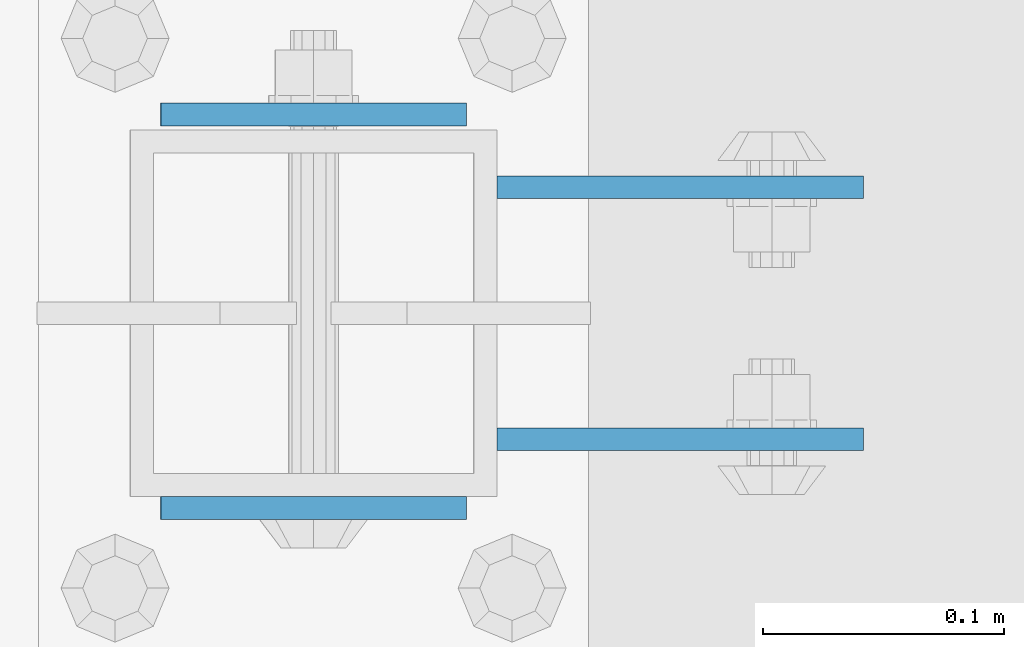
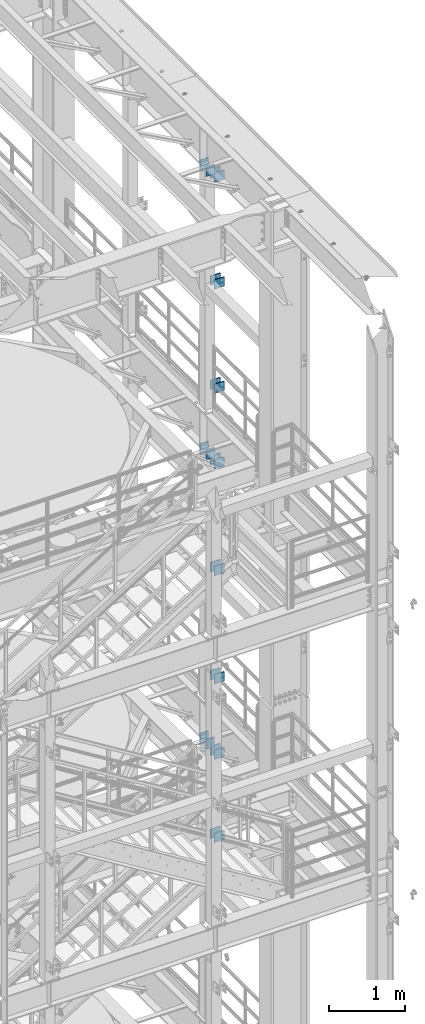
# One storey, part 1224 of 1876: 22 beams, 6 elements without a shape of their own.
"""IFC2X3 building model written with IfcOpenShell, lengths in millimetres."""

from ifc_helpers import new_model, si_unit, frame, origin_with_axes, place, context, subcontext, project, spatial, faceted_brep, material, type_object, element, aggregate, save


model = new_model("IFC2X3")

# Units and contexts
model_context = context("Model", 3, precision=1e-05, world=origin_with_axes())
body_context = subcontext(model_context, "Body", "Model", "MODEL_VIEW")
ifc_project = project(units=[si_unit("LENGTHUNIT", "METRE", prefix="MILLI"), si_unit("AREAUNIT", "SQUARE_METRE"), si_unit("VOLUMEUNIT", "CUBIC_METRE"), si_unit("MASSUNIT", "GRAM", prefix="KILO"), si_unit("TIMEUNIT", "SECOND"), si_unit("PLANEANGLEUNIT", "RADIAN"), si_unit("SOLIDANGLEUNIT", "STERADIAN"), si_unit("THERMODYNAMICTEMPERATUREUNIT", "DEGREE_CELSIUS"), si_unit("LUMINOUSINTENSITYUNIT", "LUMEN")], contexts=[model_context])

# Site, building, storey
site_placement = place(None, origin_with_axes())
site = spatial("IfcSite", under=ifc_project, at=site_placement, CompositionType="ELEMENT")
building_placement = place(site_placement, origin_with_axes())
building = spatial("IfcBuilding", under=site, at=building_placement, Name="Undefined", CompositionType="ELEMENT")
storey_placement = place(building_placement, origin_with_axes())
storey = spatial("IfcBuildingStorey", under=building, at=storey_placement, Name="Undefined", CompositionType="ELEMENT", Elevation=0.0)

# Assembly, beams
assembly_1_placement = place(storey_placement, origin_with_axes())
assembly_1 = element("IfcElementAssembly", 1, at=assembly_1_placement, inside=storey, Name="BEAM", AssemblyPlace="NOTDEFINED", PredefinedType="RIGID_FRAME")
ifc_material = material(Name="STEEL/A36")
beam_type_1 = type_object("IfcBeamType", PredefinedType="NOTDEFINED")
beam_1_placement = place(assembly_1_placement, frame((7696.20000025489, -2487.6125, 18275.3), z_axis=(0.0, 0.0, -1.0), x_axis=(1.0, 0.0, 0.0)))
beam_1 = element("IfcBeam", 2, at=beam_1_placement, type_object=beam_type_1, material=ifc_material, Name="PLATE", context=body_context, shape_type="Brep", body=[
    faceted_brep([(0.0, 4.76249999999982, -76.1999999999998), (3.63797880709171e-12, 4.76249999999982, 76.1999969482422), (152.399993896484, 4.76250000000073, 76.1999969482422), (152.4, 4.76249999999982, -76.1999999999998), (3.63797880709171e-12, -4.76249999999982, 76.1999969482422), (152.399993896484, -4.76250000000073, 76.1999969482422), (0.0, -4.76249999999982, -76.1999999999998), (152.4, -4.76249999999982, -76.1999999999998)], [[[0, 1, 2, 3]], [[4, 5, 2, 1]], [[4, 6, 7, 5]], [[6, 0, 3, 7]], [[5, 7, 3, 2]], [[6, 4, 1, 0]]]),
])
beam_2_placement = place(assembly_1_placement, frame((7696.20000025489, -2592.3875, 18275.3), z_axis=(0.0, 0.0, -1.0), x_axis=(1.0, 0.0, 0.0)))
beam_2 = element("IfcBeam", 3, at=beam_2_placement, type_object=beam_type_1, material=ifc_material, Name="PLATE", context=body_context, shape_type="Brep", body=[
    faceted_brep([(0.0, 4.76249999999982, -76.1999999999998), (3.63797880709171e-12, 4.76249999999982, 76.1999969482422), (152.399993896484, 4.76250000000073, 76.1999969482422), (152.4, 4.76249999999982, -76.1999999999998), (3.63797880709171e-12, -4.76249999999982, 76.1999969482422), (152.399993896484, -4.76250000000073, 76.1999969482422), (0.0, -4.76249999999982, -76.1999999999998), (152.4, -4.76249999999982, -76.1999999999998)], [[[0, 1, 2, 3]], [[4, 5, 2, 1]], [[4, 6, 7, 5]], [[6, 0, 3, 7]], [[5, 7, 3, 2]], [[6, 4, 1, 0]]]),
])
beam_3_placement = place(assembly_1_placement, frame((7696.20000025489, -2487.6125, 21678.9), z_axis=(0.0, 0.0, -1.0), x_axis=(1.0, 0.0, 0.0)))
beam_3 = element("IfcBeam", 4, at=beam_3_placement, type_object=beam_type_1, material=ifc_material, Name="PLATE", context=body_context, shape_type="Brep", body=[
    faceted_brep([(0.0, 4.76249999999982, -76.1999999999998), (3.63797880709171e-12, 4.76249999999982, 76.1999969482422), (152.399993896484, 4.76250000000073, 76.1999969482422), (152.4, 4.76249999999982, -76.1999999999998), (3.63797880709171e-12, -4.76249999999982, 76.1999969482422), (152.399993896484, -4.76250000000073, 76.1999969482422), (0.0, -4.76249999999982, -76.1999999999998), (152.4, -4.76249999999982, -76.1999999999998)], [[[0, 1, 2, 3]], [[4, 5, 2, 1]], [[4, 6, 7, 5]], [[6, 0, 3, 7]], [[5, 7, 3, 2]], [[6, 4, 1, 0]]]),
])
beam_4_placement = place(assembly_1_placement, frame((7696.20000025489, -2592.3875, 21678.9), z_axis=(0.0, 0.0, -1.0), x_axis=(1.0, 0.0, 0.0)))
beam_4 = element("IfcBeam", 5, at=beam_4_placement, type_object=beam_type_1, material=ifc_material, Name="PLATE", context=body_context, shape_type="Brep", body=[
    faceted_brep([(0.0, 4.76249999999982, -76.1999999999998), (3.63797880709171e-12, 4.76249999999982, 76.1999969482422), (152.399993896484, 4.76250000000073, 76.1999969482422), (152.4, 4.76249999999982, -76.1999999999998), (3.63797880709171e-12, -4.76249999999982, 76.1999969482422), (152.399993896484, -4.76250000000073, 76.1999969482422), (0.0, -4.76249999999982, -76.1999999999998), (152.4, -4.76249999999982, -76.1999999999998)], [[[0, 1, 2, 3]], [[4, 5, 2, 1]], [[4, 6, 7, 5]], [[6, 0, 3, 7]], [[5, 7, 3, 2]], [[6, 4, 1, 0]]]),
])
beam_5_placement = place(assembly_1_placement, frame((7696.20000025489, -2487.6125, 19958.05), z_axis=(0.0, 0.0, -1.0), x_axis=(1.0, 0.0, 0.0)))
beam_5 = element("IfcBeam", 6, at=beam_5_placement, type_object=beam_type_1, material=ifc_material, Name="PLATE", context=body_context, shape_type="Brep", body=[
    faceted_brep([(0.0, 4.76249999999982, -76.1999999999998), (3.63797880709171e-12, 4.76249999999982, 76.1999969482422), (152.399993896484, 4.76250000000073, 76.1999969482422), (152.4, 4.76249999999982, -76.1999999999998), (3.63797880709171e-12, -4.76249999999982, 76.1999969482422), (152.399993896484, -4.76250000000073, 76.1999969482422), (0.0, -4.76249999999982, -76.1999999999998), (152.4, -4.76249999999982, -76.1999999999998)], [[[0, 1, 2, 3]], [[4, 5, 2, 1]], [[4, 6, 7, 5]], [[6, 0, 3, 7]], [[5, 7, 3, 2]], [[6, 4, 1, 0]]]),
])
beam_6_placement = place(assembly_1_placement, frame((7696.20000025489, -2592.3875, 19958.05), z_axis=(0.0, 0.0, -1.0), x_axis=(1.0, 0.0, 0.0)))
beam_6 = element("IfcBeam", 7, at=beam_6_placement, type_object=beam_type_1, material=ifc_material, Name="PLATE", context=body_context, shape_type="Brep", body=[
    faceted_brep([(0.0, 4.76249999999982, -76.1999999999998), (3.63797880709171e-12, 4.76249999999982, 76.1999969482422), (152.399993896484, 4.76250000000073, 76.1999969482422), (152.4, 4.76249999999982, -76.1999999999998), (3.63797880709171e-12, -4.76249999999982, 76.1999969482422), (152.399993896484, -4.76250000000073, 76.1999969482422), (0.0, -4.76249999999982, -76.1999999999998), (152.4, -4.76249999999982, -76.1999999999998)], [[[0, 1, 2, 3]], [[4, 5, 2, 1]], [[4, 6, 7, 5]], [[6, 0, 3, 7]], [[5, 7, 3, 2]], [[6, 4, 1, 0]]]),
])
aggregate(assembly_1, [beam_1, beam_2, beam_3, beam_4, beam_5, beam_6])

assembly_2_placement = place(storey_placement, origin_with_axes())
assembly_2 = element("IfcElementAssembly", 8, at=assembly_2_placement, inside=storey, Name="BEAM", AssemblyPlace="NOTDEFINED", PredefinedType="RIGID_FRAME")
beam_7_placement = place(assembly_2_placement, frame((7696.2, -2487.6125, 13589.0), z_axis=(0.0, 0.0, -1.0), x_axis=(1.0, 0.0, 0.0)))
beam_7 = element("IfcBeam", 9, at=beam_7_placement, type_object=beam_type_1, material=ifc_material, Name="PLATE", context=body_context, shape_type="Brep", body=[
    faceted_brep([(0.0, 4.76249999999982, -76.1999999999998), (3.63797880709171e-12, 4.76249999999982, 76.1999969482422), (152.399993896484, 4.76250000000073, 76.1999969482422), (152.4, 4.76249999999982, -76.1999999999998), (3.63797880709171e-12, -4.76249999999982, 76.1999969482422), (152.399993896484, -4.76250000000073, 76.1999969482422), (0.0, -4.76249999999982, -76.1999999999998), (152.4, -4.76249999999982, -76.1999999999998)], [[[0, 1, 2, 3]], [[4, 5, 2, 1]], [[4, 6, 7, 5]], [[6, 0, 3, 7]], [[5, 7, 3, 2]], [[6, 4, 1, 0]]]),
])
beam_8_placement = place(assembly_2_placement, frame((7696.2, -2592.3875, 13589.0), z_axis=(0.0, 0.0, -1.0), x_axis=(1.0, 0.0, 0.0)))
beam_8 = element("IfcBeam", 10, at=beam_8_placement, type_object=beam_type_1, material=ifc_material, Name="PLATE", context=body_context, shape_type="Brep", body=[
    faceted_brep([(0.0, 4.76249999999982, -76.1999999999998), (3.63797880709171e-12, 4.76249999999982, 76.1999969482422), (152.399993896484, 4.76250000000073, 76.1999969482422), (152.4, 4.76249999999982, -76.1999999999998), (3.63797880709171e-12, -4.76249999999982, 76.1999969482422), (152.399993896484, -4.76250000000073, 76.1999969482422), (0.0, -4.76249999999982, -76.1999999999998), (152.4, -4.76249999999982, -76.1999999999998)], [[[0, 1, 2, 3]], [[4, 5, 2, 1]], [[4, 6, 7, 5]], [[6, 0, 3, 7]], [[5, 7, 3, 2]], [[6, 4, 1, 0]]]),
])
beam_9_placement = place(assembly_2_placement, frame((7696.2, -2487.6125, 17056.1), z_axis=(0.0, 0.0, -1.0), x_axis=(1.0, 0.0, 0.0)))
beam_9 = element("IfcBeam", 11, at=beam_9_placement, type_object=beam_type_1, material=ifc_material, Name="PLATE", context=body_context, shape_type="Brep", body=[
    faceted_brep([(0.0, 4.76249999999982, -76.1999999999998), (3.63797880709171e-12, 4.76249999999982, 76.1999969482422), (152.399993896484, 4.76250000000073, 76.1999969482422), (152.4, 4.76249999999982, -76.1999999999998), (3.63797880709171e-12, -4.76249999999982, 76.1999969482422), (152.399993896484, -4.76250000000073, 76.1999969482422), (0.0, -4.76249999999982, -76.1999999999998), (152.4, -4.76249999999982, -76.1999999999998)], [[[0, 1, 2, 3]], [[4, 5, 2, 1]], [[4, 6, 7, 5]], [[6, 0, 3, 7]], [[5, 7, 3, 2]], [[6, 4, 1, 0]]]),
])
beam_10_placement = place(assembly_2_placement, frame((7696.2, -2592.3875, 17056.1), z_axis=(0.0, 0.0, -1.0), x_axis=(1.0, 0.0, 0.0)))
beam_10 = element("IfcBeam", 12, at=beam_10_placement, type_object=beam_type_1, material=ifc_material, Name="PLATE", context=body_context, shape_type="Brep", body=[
    faceted_brep([(0.0, 4.76249999999982, -76.1999999999998), (3.63797880709171e-12, 4.76249999999982, 76.1999969482422), (152.399993896484, 4.76250000000073, 76.1999969482422), (152.4, 4.76249999999982, -76.1999999999998), (3.63797880709171e-12, -4.76249999999982, 76.1999969482422), (152.399993896484, -4.76250000000073, 76.1999969482422), (0.0, -4.76249999999982, -76.1999999999998), (152.4, -4.76249999999982, -76.1999999999998)], [[[0, 1, 2, 3]], [[4, 5, 2, 1]], [[4, 6, 7, 5]], [[6, 0, 3, 7]], [[5, 7, 3, 2]], [[6, 4, 1, 0]]]),
])
beam_11_placement = place(assembly_2_placement, frame((7696.2, -2487.6125, 15335.25), z_axis=(0.0, 0.0, -1.0), x_axis=(1.0, 0.0, 0.0)))
beam_11 = element("IfcBeam", 13, at=beam_11_placement, type_object=beam_type_1, material=ifc_material, Name="PLATE", context=body_context, shape_type="Brep", body=[
    faceted_brep([(0.0, 4.76249999999982, -76.1999999999998), (3.63797880709171e-12, 4.76249999999982, 76.1999969482422), (152.399993896484, 4.76250000000073, 76.1999969482422), (152.4, 4.76249999999982, -76.1999999999998), (3.63797880709171e-12, -4.76249999999982, 76.1999969482422), (152.399993896484, -4.76250000000073, 76.1999969482422), (0.0, -4.76249999999982, -76.1999999999998), (152.4, -4.76249999999982, -76.1999999999998)], [[[0, 1, 2, 3]], [[4, 5, 2, 1]], [[4, 6, 7, 5]], [[6, 0, 3, 7]], [[5, 7, 3, 2]], [[6, 4, 1, 0]]]),
])
beam_12_placement = place(assembly_2_placement, frame((7696.2, -2592.3875, 15335.25), z_axis=(0.0, 0.0, -1.0), x_axis=(1.0, 0.0, 0.0)))
beam_12 = element("IfcBeam", 14, at=beam_12_placement, type_object=beam_type_1, material=ifc_material, Name="PLATE", context=body_context, shape_type="Brep", body=[
    faceted_brep([(0.0, 4.76249999999982, -76.1999999999998), (3.63797880709171e-12, 4.76249999999982, 76.1999969482422), (152.399993896484, 4.76250000000073, 76.1999969482422), (152.4, 4.76249999999982, -76.1999999999998), (3.63797880709171e-12, -4.76249999999982, 76.1999969482422), (152.399993896484, -4.76250000000073, 76.1999969482422), (0.0, -4.76249999999982, -76.1999999999998), (152.4, -4.76249999999982, -76.1999999999998)], [[[0, 1, 2, 3]], [[4, 5, 2, 1]], [[4, 6, 7, 5]], [[6, 0, 3, 7]], [[5, 7, 3, 2]], [[6, 4, 1, 0]]]),
])
aggregate(assembly_2, [beam_7, beam_8, beam_9, beam_10, beam_11, beam_12])

assembly_3_placement = place(storey_placement, origin_with_axes())
assembly_3 = element("IfcElementAssembly", 15, at=assembly_3_placement, inside=storey, Name="BEAM", AssemblyPlace="NOTDEFINED", PredefinedType="RIGID_FRAME")
beam_13_placement = place(assembly_3_placement, frame((7696.2, -2487.6125, 12369.8), z_axis=(0.0, 0.0, -1.0), x_axis=(1.0, 0.0, 0.0)))
beam_13 = element("IfcBeam", 16, at=beam_13_placement, type_object=beam_type_1, material=ifc_material, Name="PLATE", context=body_context, shape_type="Brep", body=[
    faceted_brep([(0.0, 4.76249999999982, -76.1999999999998), (3.63797880709171e-12, 4.76249999999982, 76.1999969482422), (152.399993896484, 4.76250000000073, 76.1999969482422), (152.4, 4.76249999999982, -76.1999999999998), (3.63797880709171e-12, -4.76249999999982, 76.1999969482422), (152.399993896484, -4.76250000000073, 76.1999969482422), (0.0, -4.76249999999982, -76.1999999999998), (152.4, -4.76249999999982, -76.1999999999998)], [[[0, 1, 2, 3]], [[4, 5, 2, 1]], [[4, 6, 7, 5]], [[6, 0, 3, 7]], [[5, 7, 3, 2]], [[6, 4, 1, 0]]]),
])
beam_14_placement = place(assembly_3_placement, frame((7696.2, -2592.3875, 12369.8), z_axis=(0.0, 0.0, -1.0), x_axis=(1.0, 0.0, 0.0)))
beam_14 = element("IfcBeam", 17, at=beam_14_placement, type_object=beam_type_1, material=ifc_material, Name="PLATE", context=body_context, shape_type="Brep", body=[
    faceted_brep([(0.0, 4.76249999999982, -76.1999999999998), (3.63797880709171e-12, 4.76249999999982, 76.1999969482422), (152.399993896484, 4.76250000000073, 76.1999969482422), (152.4, 4.76249999999982, -76.1999999999998), (3.63797880709171e-12, -4.76249999999982, 76.1999969482422), (152.399993896484, -4.76250000000073, 76.1999969482422), (0.0, -4.76249999999982, -76.1999999999998), (152.4, -4.76249999999982, -76.1999999999998)], [[[0, 1, 2, 3]], [[4, 5, 2, 1]], [[4, 6, 7, 5]], [[6, 0, 3, 7]], [[5, 7, 3, 2]], [[6, 4, 1, 0]]]),
])
beam_15_placement = place(assembly_3_placement, frame((7696.2, -2487.6125, 11029.95), z_axis=(0.0, 0.0, -1.0), x_axis=(1.0, 0.0, 0.0)))
beam_15 = element("IfcBeam", 18, at=beam_15_placement, type_object=beam_type_1, material=ifc_material, Name="PLATE", context=body_context, shape_type="Brep", body=[
    faceted_brep([(0.0, 4.76249999999982, -76.1999999999998), (3.63797880709171e-12, 4.76249999999982, 76.1999969482422), (152.399993896484, 4.76250000000073, 76.1999969482422), (152.4, 4.76249999999982, -76.1999999999998), (3.63797880709171e-12, -4.76249999999982, 76.1999969482422), (152.399993896484, -4.76250000000073, 76.1999969482422), (0.0, -4.76249999999982, -76.1999999999998), (152.4, -4.76249999999982, -76.1999999999998)], [[[0, 1, 2, 3]], [[4, 5, 2, 1]], [[4, 6, 7, 5]], [[6, 0, 3, 7]], [[5, 7, 3, 2]], [[6, 4, 1, 0]]]),
])
beam_16_placement = place(assembly_3_placement, frame((7696.2, -2592.3875, 11029.95), z_axis=(0.0, 0.0, -1.0), x_axis=(1.0, 0.0, 0.0)))
beam_16 = element("IfcBeam", 19, at=beam_16_placement, type_object=beam_type_1, material=ifc_material, Name="PLATE", context=body_context, shape_type="Brep", body=[
    faceted_brep([(0.0, 4.76249999999982, -76.1999999999998), (3.63797880709171e-12, 4.76249999999982, 76.1999969482422), (152.399993896484, 4.76250000000073, 76.1999969482422), (152.4, 4.76249999999982, -76.1999999999998), (3.63797880709171e-12, -4.76249999999982, 76.1999969482422), (152.399993896484, -4.76250000000073, 76.1999969482422), (0.0, -4.76249999999982, -76.1999999999998), (152.4, -4.76249999999982, -76.1999999999998)], [[[0, 1, 2, 3]], [[4, 5, 2, 1]], [[4, 6, 7, 5]], [[6, 0, 3, 7]], [[5, 7, 3, 2]], [[6, 4, 1, 0]]]),
])
aggregate(assembly_3, [beam_13, beam_14, beam_15, beam_16])

assembly_4_placement = place(storey_placement, origin_with_axes())
assembly_4 = element("IfcElementAssembly", 20, at=assembly_4_placement, inside=storey, Name="BEAM", AssemblyPlace="NOTDEFINED", PredefinedType="RIGID_FRAME")
beam_type_2 = type_object("IfcBeamType", PredefinedType="NOTDEFINED")
beam_17_placement = place(assembly_4_placement, frame((7556.36848042001, -2457.45, 12604.7488224823), z_axis=(2.95459999824743e-05, 0.0, -0.999999999563517), x_axis=(0.999999999563517, 0.0, 2.95459999828704e-05)))
beam_17 = element("IfcBeam", 21, at=beam_17_placement, type_object=beam_type_2, material=ifc_material, Name="PLATE", context=body_context, shape_type="Brep", body=[
    faceted_brep([(0.0, 4.76249999999982, -82.5499999999993), (0.0, 4.76249999999982, 82.5499999999993), (127.0, 4.76249999999982, 82.5499999999993), (127.0, 4.76249999999982, -82.5499999999993), (0.0, -4.76249999999982, 82.5499999999993), (127.0, -4.76249999999982, 82.5499999999993), (0.0, -4.76249999999982, -82.5499999999993), (127.0, -4.76249999999982, -82.5499999999993)], [[[0, 1, 2, 3]], [[1, 4, 5, 2]], [[4, 6, 7, 5]], [[6, 0, 3, 7]], [[5, 7, 3, 2]], [[6, 4, 1, 0]]]),
])
beam_18_placement = place(assembly_4_placement, frame((7556.36848042001, -2620.9625, 12604.7488224823), z_axis=(2.95459999824743e-05, 0.0, -0.999999999563517), x_axis=(0.999999999563517, 0.0, 2.95459999828704e-05)))
beam_18 = element("IfcBeam", 22, at=beam_18_placement, type_object=beam_type_2, material=ifc_material, Name="PLATE", context=body_context, shape_type="Brep", body=[
    faceted_brep([(0.0, 4.76249999999982, -82.5499999999993), (0.0, 4.76249999999982, 82.5499999999993), (127.0, 4.76249999999982, 82.5499999999993), (127.0, 4.76249999999982, -82.5499999999993), (0.0, -4.76249999999982, 82.5499999999993), (127.0, -4.76249999999982, 82.5499999999993), (0.0, -4.76249999999982, -82.5499999999993), (127.0, -4.76249999999982, -82.5499999999993)], [[[0, 1, 2, 3]], [[1, 4, 5, 2]], [[4, 6, 7, 5]], [[6, 0, 3, 7]], [[5, 7, 3, 2]], [[6, 4, 1, 0]]]),
])
aggregate(assembly_4, [beam_17, beam_18])

assembly_5_placement = place(storey_placement, origin_with_axes())
assembly_5 = element("IfcElementAssembly", 23, at=assembly_5_placement, inside=storey, Name="BEAM", AssemblyPlace="NOTDEFINED", PredefinedType="RIGID_FRAME")
beam_19_placement = place(assembly_5_placement, frame((7556.5, -2457.45, 17278.35), z_axis=(0.0, 0.0, -1.0), x_axis=(1.0, 0.0, 0.0)))
beam_19 = element("IfcBeam", 24, at=beam_19_placement, type_object=beam_type_2, material=ifc_material, Name="PLATE", context=body_context, shape_type="Brep", body=[
    faceted_brep([(0.0, 4.76249999999982, -82.5499999999993), (0.0, 4.76249999999982, 82.5499999999993), (127.0, 4.76249999999982, 82.5499999999993), (127.0, 4.76249999999982, -82.5499999999993), (0.0, -4.76249999999982, 82.5499999999993), (127.0, -4.76249999999982, 82.5499999999993), (0.0, -4.76249999999982, -82.5499999999993), (127.0, -4.76249999999982, -82.5499999999993)], [[[0, 1, 2, 3]], [[1, 4, 5, 2]], [[4, 6, 7, 5]], [[6, 0, 3, 7]], [[5, 7, 3, 2]], [[6, 4, 1, 0]]]),
])
beam_20_placement = place(assembly_5_placement, frame((7556.5, -2620.9625, 17278.35), z_axis=(0.0, 0.0, -1.0), x_axis=(1.0, 0.0, 0.0)))
beam_20 = element("IfcBeam", 25, at=beam_20_placement, type_object=beam_type_2, material=ifc_material, Name="PLATE", context=body_context, shape_type="Brep", body=[
    faceted_brep([(0.0, 4.76249999999982, -82.5499999999993), (0.0, 4.76249999999982, 82.5499999999993), (127.0, 4.76249999999982, 82.5499999999993), (127.0, 4.76249999999982, -82.5499999999993), (0.0, -4.76249999999982, 82.5499999999993), (127.0, -4.76249999999982, 82.5499999999993), (0.0, -4.76249999999982, -82.5499999999993), (127.0, -4.76249999999982, -82.5499999999993)], [[[0, 1, 2, 3]], [[1, 4, 5, 2]], [[4, 6, 7, 5]], [[6, 0, 3, 7]], [[5, 7, 3, 2]], [[6, 4, 1, 0]]]),
])
aggregate(assembly_5, [beam_19, beam_20])

assembly_6_placement = place(storey_placement, origin_with_axes())
assembly_6 = element("IfcElementAssembly", 26, at=assembly_6_placement, inside=storey, Name="BEAM", AssemblyPlace="NOTDEFINED", PredefinedType="RIGID_FRAME")
beam_21_placement = place(assembly_6_placement, frame((7556.5, -2457.45, 21850.35), z_axis=(0.0, 0.0, -1.0), x_axis=(1.0, 0.0, 0.0)))
beam_21 = element("IfcBeam", 27, at=beam_21_placement, type_object=beam_type_2, material=ifc_material, Name="PLATE", context=body_context, shape_type="Brep", body=[
    faceted_brep([(0.0, 4.76249999999982, -82.5499999999993), (0.0, 4.76249999999982, 82.5499999999993), (127.0, 4.76249999999982, 82.5499999999993), (127.0, 4.76249999999982, -82.5499999999993), (0.0, -4.76249999999982, 82.5499999999993), (127.0, -4.76249999999982, 82.5499999999993), (0.0, -4.76249999999982, -82.5499999999993), (127.0, -4.76249999999982, -82.5499999999993)], [[[0, 1, 2, 3]], [[1, 4, 5, 2]], [[4, 6, 7, 5]], [[6, 0, 3, 7]], [[5, 7, 3, 2]], [[6, 4, 1, 0]]]),
])
beam_22_placement = place(assembly_6_placement, frame((7556.5, -2620.9625, 21850.35), z_axis=(0.0, 0.0, -1.0), x_axis=(1.0, 0.0, 0.0)))
beam_22 = element("IfcBeam", 28, at=beam_22_placement, type_object=beam_type_2, material=ifc_material, Name="PLATE", context=body_context, shape_type="Brep", body=[
    faceted_brep([(0.0, 4.76249999999982, -82.5499999999993), (0.0, 4.76249999999982, 82.5499999999993), (127.0, 4.76249999999982, 82.5499999999993), (127.0, 4.76249999999982, -82.5499999999993), (0.0, -4.76249999999982, 82.5499999999993), (127.0, -4.76249999999982, 82.5499999999993), (0.0, -4.76249999999982, -82.5499999999993), (127.0, -4.76249999999982, -82.5499999999993)], [[[0, 1, 2, 3]], [[1, 4, 5, 2]], [[4, 6, 7, 5]], [[6, 0, 3, 7]], [[5, 7, 3, 2]], [[6, 4, 1, 0]]]),
])
aggregate(assembly_6, [beam_21, beam_22])

save(model, "model.ifc")
